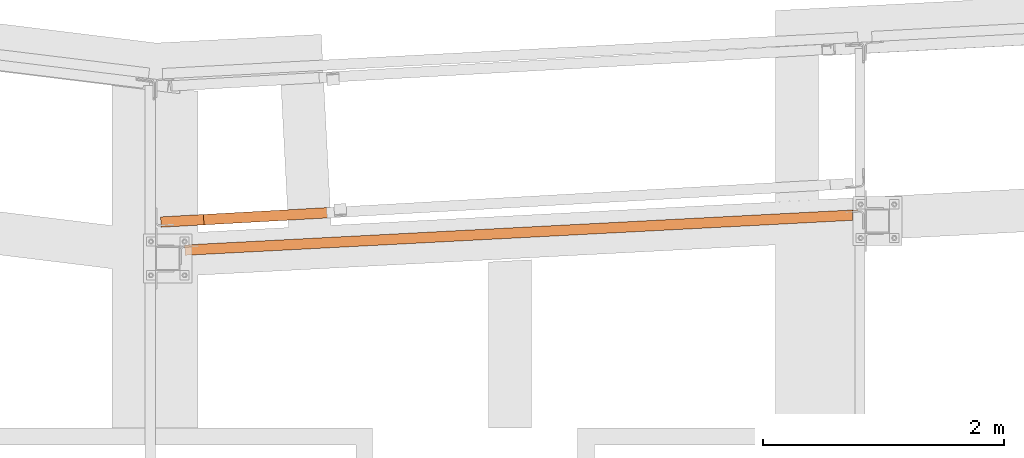
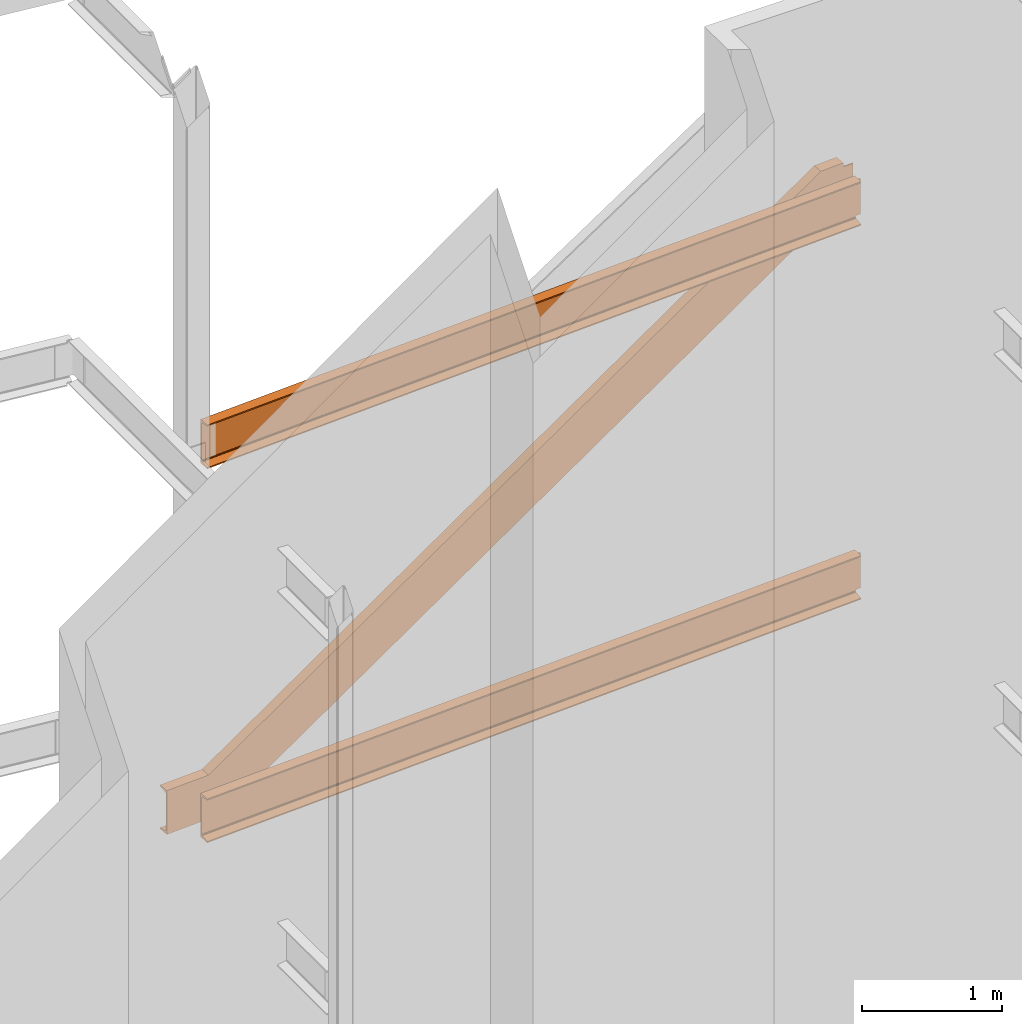
# One storey, part 18 of 89: 3 proxies.
"""IFC4 building model written with IfcOpenShell, lengths in feet."""

import ifcopenshell
import ifcopenshell.guid

model = None  # the IFC model being written
_history = None  # IfcOwnerHistory: only IFC2X3 demands one
_inside = {}  # id of a spatial element -> (the spatial element, [elements in it])
_under = {}  # id of a project, library or spatial element -> (it, [spatial elements below it])
_declared = {}  # id of a project -> (the project, [libraries it declares])
_typed = {}  # id of a type object -> (the type object, [elements of that type])
_made_of = {}  # id of a material, layer set ... -> (it, [elements and type objects made of it])


def new_model(schema):
    """Start an empty IFC model of exactly this schema.

    Asked for "IFC4X3", IfcOpenShell would pick the latest addendum, in which some entities
    have other attributes; the version numbers below select the first issue.
    IFC2X3 requires an IfcOwnerHistory on every rooted entity: one is made here for all.
    """
    global model, _history
    if schema == "IFC4X3":
        model = ifcopenshell.file(schema_version=(4, 3, 0, 0))
    else:
        model = ifcopenshell.file(schema=schema)
    _inside.clear()
    _under.clear()
    _declared.clear()
    _typed.clear()
    _made_of.clear()
    _history = None
    if model.schema == "IFC2X3":
        org = make("IfcOrganization", Name="unknown")
        user = make(
            "IfcPersonAndOrganization",
            ThePerson=make("IfcPerson", FamilyName="unknown"),
            TheOrganization=org,
        )
        app = make(
            "IfcApplication",
            ApplicationDeveloper=org,
            Version="unknown",
            ApplicationFullName="unknown",
            ApplicationIdentifier="unknown",
        )
        _history = make(
            "IfcOwnerHistory",
            OwningUser=user,
            OwningApplication=app,
            ChangeAction="ADDED",
            CreationDate=0,
        )
    return model


def make(cls, **values):
    """One entity of the class cls with the attributes given. An attribute that is None is left unset."""
    return model.create_entity(
        cls, **{name: value for name, value in values.items() if value is not None}
    )


def entity(cls, *values):
    """Any entity or typed value of the class cls, its attributes in the order of the schema. None: left unset."""
    e = model.create_entity(cls)
    for i, value in enumerate(values):
        if value is not None:
            e[i] = value
    return e


def rooted(cls, **values):
    """An entity with a GlobalId (a new one), such as an element, a storey or a relation."""
    return make(cls, GlobalId=ifcopenshell.guid.new(), OwnerHistory=_history, **values)


def si_unit(unit_type, name, prefix=None):
    """IfcSIUnit, for example si_unit("LENGTHUNIT", "METRE", prefix="MILLI")."""
    return make("IfcSIUnit", UnitType=unit_type, Prefix=prefix, Name=name)


def converted_unit(unit_type, name, factor, base, dimensions=None, offset=None):
    """IfcConversionBasedUnit, such as the inch: factor (a typed value) times the base unit."""
    return make(
        "IfcConversionBasedUnit"
        if offset is None
        else "IfcConversionBasedUnitWithOffset",
        ConversionOffset=offset,
        Dimensions=None
        if dimensions is None
        else entity("IfcDimensionalExponents", *dimensions),
        UnitType=unit_type,
        Name=name,
        ConversionFactor=make(
            "IfcMeasureWithUnit", ValueComponent=factor, UnitComponent=base
        ),
    )


def derived_unit(unit_type, elements):
    """IfcDerivedUnit: a product of units, each with its exponent."""
    return make(
        "IfcDerivedUnit",
        Elements=[
            make("IfcDerivedUnitElement", Unit=unit, Exponent=power)
            for unit, power in elements
        ],
        UnitType=unit_type,
    )


def assignment(units):
    """IfcUnitAssignment: the units of a project."""
    return None if units is None else make("IfcUnitAssignment", Units=units)


def point(xyz):
    """IfcCartesianPoint."""
    return None if xyz is None else make("IfcCartesianPoint", Coordinates=xyz)


def direction(xyz):
    """IfcDirection."""
    return None if xyz is None else make("IfcDirection", DirectionRatios=xyz)


def frame(location, z_axis=None, x_axis=None):
    """IfcAxis2Placement3D, a coordinate frame: its origin and axes. An axis left out is left unset."""
    return make(
        "IfcAxis2Placement3D",
        Location=point(location),
        Axis=direction(z_axis),
        RefDirection=direction(x_axis),
    )


def origin():
    """The frame at (0, 0, 0) with its axes left unset."""
    return frame((0.0, 0.0, 0.0))


def place(relative_to, where):
    """IfcLocalPlacement: puts the frame where relative to a parent placement (None: the world)."""
    return make(
        "IfcLocalPlacement", PlacementRelTo=relative_to, RelativePlacement=where
    )


def context(
    kind, dimensions, precision=None, world=None, true_north=None, identifier=None
):
    """IfcGeometricRepresentationContext, for example the 3D "Model" context."""
    return make(
        "IfcGeometricRepresentationContext",
        ContextIdentifier=identifier,
        ContextType=kind,
        CoordinateSpaceDimension=dimensions,
        Precision=precision,
        WorldCoordinateSystem=world,
        TrueNorth=true_north,
    )


def subcontext(parent, identifier, kind, view, scale=None):
    """IfcGeometricRepresentationSubContext, for example "Body" below "Model"."""
    return make(
        "IfcGeometricRepresentationSubContext",
        ContextIdentifier=identifier,
        ContextType=kind,
        ParentContext=parent,
        TargetScale=scale,
        TargetView=view,
    )


def project(units=None, contexts=None):
    """IfcProject with its units and contexts."""
    return rooted(
        "IfcProject",
        Name="project",
        RepresentationContexts=contexts,
        UnitsInContext=assignment(units),
    )


def spatial(cls, under=None, at=None, **own):
    """A site, building, storey or space (cls), placed at a placement, below another one or the project."""
    s = rooted(cls, ObjectPlacement=at, **own)
    if under is not None:
        _under.setdefault(under.id(), (under, []))[1].append(s)
    return s


def faces_of(points, faces, orient=None, outer=None):
    """IfcFace entities. A face is a list of loops; a loop is a list of indices into points, from 0.

    orient and outer hold one flag for each loop. By default every Orientation is true, the
    first loop of a face is its IfcFaceOuterBound and the others are IfcFaceBound.
    """
    made = []
    for i, loops in enumerate(faces):
        bounds = []
        for j, loop in enumerate(loops):
            is_outer = j == 0 if outer is None else outer[i][j]
            bounds.append(
                make(
                    "IfcFaceOuterBound" if is_outer else "IfcFaceBound",
                    Bound=make("IfcPolyLoop", Polygon=[points[k] for k in loop]),
                    Orientation=True if orient is None else orient[i][j],
                )
            )
        made.append(make("IfcFace", Bounds=bounds))
    return made


def face_set(faces, orient=None, outer=None):
    """The faces of one IfcConnectedFaceSet. surface_model builds it on its shared points."""
    return ("IfcConnectedFaceSet", faces, orient, outer)


def faceted_brep(points, faces, orient=None, outer=None, voids=None):
    """IfcFacetedBrep: a solid bounded by flat faces; with voids (closed shells), ...WithVoids."""
    shared = [point(p) for p in points]
    hull = make("IfcClosedShell", CfsFaces=faces_of(shared, faces, orient, outer))
    if voids is None:
        return make("IfcFacetedBrep", Outer=hull)
    return make(
        "IfcFacetedBrepWithVoids",
        Outer=hull,
        Voids=[
            make(cls, CfsFaces=faces_of(shared, fs, o, b)) for cls, fs, o, b in voids
        ],
    )


def surface_model(cls, points, shells):
    """IfcFaceBasedSurfaceModel or IfcShellBasedSurfaceModel (cls): surfaces that need not close."""
    shared = [point(p) for p in points]
    made = [make(c, CfsFaces=faces_of(shared, fs, o, b)) for c, fs, o, b in shells]
    if cls == "IfcFaceBasedSurfaceModel":
        return make(cls, FbsmFaces=made)
    return make(cls, SbsmBoundary=made)


def shape(context_of_items, identifier, shape_type, items):
    """IfcShapeRepresentation: the items that make up one representation, for example the "Body"."""
    return make(
        "IfcShapeRepresentation",
        ContextOfItems=context_of_items,
        RepresentationIdentifier=identifier,
        RepresentationType=shape_type,
        Items=items,
    )


def source(mapping_origin, context_of_items, identifier, shape_type, items):
    """IfcRepresentationMap: a shape defined once, which mapped items show again and again."""
    return make(
        "IfcRepresentationMap",
        MappingOrigin=mapping_origin,
        MappedRepresentation=shape(context_of_items, identifier, shape_type, items),
    )


def transform(
    local_origin,
    x_axis=None,
    y_axis=None,
    z_axis=None,
    scale=None,
    scale2=None,
    scale3=None,
    uniform=True,
):
    """IfcCartesianTransformationOperator3D, or its non-uniform kind. x_axis, y_axis, z_axis: its Axis1, 2, 3."""
    if uniform:
        return make(
            "IfcCartesianTransformationOperator3D",
            Axis1=direction(x_axis),
            Axis2=direction(y_axis),
            LocalOrigin=point(local_origin),
            Scale=scale,
            Axis3=direction(z_axis),
        )
    return make(
        "IfcCartesianTransformationOperator3DnonUniform",
        Axis1=direction(x_axis),
        Axis2=direction(y_axis),
        LocalOrigin=point(local_origin),
        Scale=scale,
        Axis3=direction(z_axis),
        Scale2=scale2,
        Scale3=scale3,
    )


def mapped(mapping_source, mapping_target):
    """IfcMappedItem: shows the shape of a source again, moved by a transform."""
    return make(
        "IfcMappedItem", MappingSource=mapping_source, MappingTarget=mapping_target
    )


def material(Name=None, Category=None):
    """IfcMaterial."""
    return make("IfcMaterial", Name=Name, Category=Category)


def constituent(of_material, Name=None, Category=None, fraction=None):
    """IfcMaterialConstituent: one of the materials an element consists of."""
    return make(
        "IfcMaterialConstituent",
        Name=Name,
        Material=of_material,
        Fraction=fraction,
        Category=Category,
    )


def constituent_set(constituents=None, Name=None):
    """IfcMaterialConstituentSet."""
    return make(
        "IfcMaterialConstituentSet", Name=Name, MaterialConstituents=constituents
    )


def made_of(thing, what):
    """Note that an element or type object is made of a material, layer set ...; save() writes the relation."""
    if what is not None:
        _made_of.setdefault(what.id(), (what, []))[1].append(thing)
    return thing


def type_object(cls, material=None, **own):
    """A type object (cls), such as IfcWallType, which elements share."""
    return made_of(rooted(cls, **own), material)


def type_shapes(of_type, sources):
    """Give a type object the sources (RepresentationMaps) that its elements show as mapped items."""
    of_type.RepresentationMaps = sources


def element(
    cls,
    number,
    at=None,
    inside=None,
    cuts=None,
    type_object=None,
    material=None,
    context=None,
    identifier="Body",
    shape_type=None,
    held_by="IfcProductDefinitionShape",
    body=None,
    shapes=None,
    **own,
):
    """One element of the class cls, such as IfcWall. Its Tag is "e" and its number.

    at: its placement. inside: the storey or other place that contains it. cuts: it is an
    opening in that element (IfcRelVoidsElement). A single representation is given by context,
    identifier, shape_type and body (its items); several are given by shapes. held_by: the class
    of the entity that holds the representations. save() writes the other relations.
    """
    e = rooted(cls, Tag="e%d" % number, ObjectPlacement=at, **own)
    if body is not None:
        shapes = [shape(context, identifier, shape_type, body)]
    if shapes is not None:
        e.Representation = make(held_by, Representations=shapes)
    if inside is not None:
        _inside.setdefault(inside.id(), (inside, []))[1].append(e)
    if cuts is not None:
        rooted(
            "IfcRelVoidsElement", RelatingBuildingElement=cuts, RelatedOpeningElement=e
        )
    if type_object is not None:
        _typed.setdefault(type_object.id(), (type_object, []))[1].append(e)
    return made_of(e, material)


def aggregate(whole, parts):
    """IfcRelAggregates: a whole, such as a stair, and the parts it consists of."""
    return rooted("IfcRelAggregates", RelatingObject=whole, RelatedObjects=parts)


def save(model, path):
    """Write the relations noted so far, then the file.

    IfcRelAggregates (storeys below a building ...), IfcRelContainedInSpatialStructure (elements
    in a storey), IfcRelDefinesByType, IfcRelAssociatesMaterial and IfcRelDeclares: one each for
    every whole, place, type object, material and project.
    """
    for whole, parts in _under.values():
        aggregate(whole, parts)
    for where, things in _inside.values():
        rooted(
            "IfcRelContainedInSpatialStructure",
            RelatedElements=things,
            RelatingStructure=where,
        )
    for kind, things in _typed.values():
        rooted("IfcRelDefinesByType", RelatedObjects=things, RelatingType=kind)
    for what, things in _made_of.values():
        rooted("IfcRelAssociatesMaterial", RelatedObjects=things, RelatingMaterial=what)
    for by, libraries in _declared.values():
        rooted("IfcRelDeclares", RelatingContext=by, RelatedDefinitions=libraries)
    model.write(path)


model = new_model("IFC4")

# Units and contexts
model_context = context("Model", 3, precision=0.0001, world=origin(), true_north=direction((6.12303176911189e-17, 1.0)))
body_context = subcontext(model_context, "Body", "Model", "MODEL_VIEW")
ifc_project = project(units=[converted_unit("LENGTHUNIT", "FOOT", entity("IfcRatioMeasure", 0.3048), si_unit("LENGTHUNIT", "METRE"), dimensions=[1, 0, 0, 0, 0, 0, 0]), converted_unit("AREAUNIT", "SQUARE FOOT", entity("IfcRatioMeasure", 0.09290304), si_unit("AREAUNIT", "SQUARE_METRE"), dimensions=[2, 0, 0, 0, 0, 0, 0]), converted_unit("VOLUMEUNIT", "CUBIC FOOT", entity("IfcRatioMeasure", 0.028316846592), si_unit("VOLUMEUNIT", "CUBIC_METRE"), dimensions=[3, 0, 0, 0, 0, 0, 0]), si_unit("PLANEANGLEUNIT", "RADIAN"), si_unit("MASSUNIT", "GRAM", prefix="KILO"), derived_unit("MASSDENSITYUNIT", [(si_unit("MASSUNIT", "GRAM", prefix="KILO"), 1), (si_unit("LENGTHUNIT", "METRE"), -3)]), derived_unit("MOMENTOFINERTIAUNIT", [(si_unit("LENGTHUNIT", "METRE"), 4)]), si_unit("TIMEUNIT", "SECOND"), si_unit("FREQUENCYUNIT", "HERTZ"), si_unit("THERMODYNAMICTEMPERATUREUNIT", "DEGREE_CELSIUS"), derived_unit("THERMALTRANSMITTANCEUNIT", [(si_unit("MASSUNIT", "GRAM", prefix="KILO"), 1), (si_unit("THERMODYNAMICTEMPERATUREUNIT", "KELVIN"), -1), (si_unit("TIMEUNIT", "SECOND"), -3)]), derived_unit("VOLUMETRICFLOWRATEUNIT", [(si_unit("LENGTHUNIT", "METRE"), 3), (si_unit("TIMEUNIT", "SECOND"), -1)]), si_unit("ELECTRICCURRENTUNIT", "AMPERE"), si_unit("ELECTRICVOLTAGEUNIT", "VOLT"), si_unit("POWERUNIT", "WATT"), si_unit("FORCEUNIT", "NEWTON"), si_unit("ILLUMINANCEUNIT", "LUX"), si_unit("LUMINOUSFLUXUNIT", "LUMEN"), si_unit("LUMINOUSINTENSITYUNIT", "CANDELA"), derived_unit("USERDEFINED", [(si_unit("MASSUNIT", "GRAM", prefix="KILO"), -1), (si_unit("LENGTHUNIT", "METRE"), -2), (si_unit("TIMEUNIT", "SECOND"), 3), (si_unit("LUMINOUSFLUXUNIT", "LUMEN"), 1)]), derived_unit("LINEARVELOCITYUNIT", [(si_unit("LENGTHUNIT", "METRE"), 1), (si_unit("TIMEUNIT", "SECOND"), -1)]), si_unit("PRESSUREUNIT", "PASCAL"), derived_unit("USERDEFINED", [(si_unit("LENGTHUNIT", "METRE"), -2), (si_unit("MASSUNIT", "GRAM", prefix="KILO"), 1), (si_unit("TIMEUNIT", "SECOND"), -2)]), derived_unit("LINEARFORCEUNIT", [(si_unit("MASSUNIT", "GRAM", prefix="KILO"), 1), (si_unit("LENGTHUNIT", "METRE"), 1), (si_unit("TIMEUNIT", "SECOND"), -2), (si_unit("LENGTHUNIT", "METRE"), -1)]), derived_unit("PLANARFORCEUNIT", [(si_unit("MASSUNIT", "GRAM", prefix="KILO"), 1), (si_unit("LENGTHUNIT", "METRE"), 1), (si_unit("TIMEUNIT", "SECOND"), -2), (si_unit("LENGTHUNIT", "METRE"), -2)])], contexts=[model_context])

# Site, building, storey
site_placement = place(None, origin())
site = spatial("IfcSite", under=ifc_project, at=site_placement, CompositionType="ELEMENT")
building_placement = place(site_placement, frame((-472.238160486, -49.138065117, 0.0)))
building = spatial("IfcBuilding", under=site, at=building_placement, CompositionType="ELEMENT")
storey_placement = place(building_placement, origin())
storey = spatial("IfcBuildingStorey", under=building, at=storey_placement, Name="Level 1", CompositionType="ELEMENT", Elevation=0.0)

# Proxies
ifc_material_1 = material(Name="Color 7720", Category="Materials")
ifc_material_2 = material()
ifc_constituent_1 = constituent(ifc_material_2)
ifc_constituent_2 = constituent(ifc_material_1, Name="Color 7720", Category="Materials")
ifc_constituent_set_1 = constituent_set(constituents=[ifc_constituent_1, ifc_constituent_2])
building_element_proxy_type_1 = type_object("IfcBuildingElementProxyType", Name="B_103", PredefinedType="NOTDEFINED", material=ifc_constituent_set_1)
shared_shape_1 = source(origin(), body_context, "Body", "Brep", [
    faceted_brep([(0.0, 0.282945034847216, 1.25), (0.0, 0.282945034847216, 0.0), (0.0148285209357937, 0.0, 0.0), (0.0148285209357937, 0.0, 0.0333340558078792), (0.00405689048204749, 0.205534953036704, 0.0676357025785492), (0.00314508419057802, 0.222933253516999, 0.0738152303316895), (0.00240032733222506, 0.2371440609312, 0.0856142600983691), (0.00191364833358421, 0.246430449426384, 0.10159064723195), (0.00174453187503332, 0.249657383688714, 0.11979166666667), (0.00174453187503332, 0.249657383688714, 1.13020833333333), (0.00191364833358421, 0.246430449426384, 1.14840935276805), (0.00240032733222506, 0.2371440609312, 1.16438573990163), (0.00314508419057802, 0.222933253516999, 1.17618476966831), (0.00405689048204749, 0.205534953036704, 1.18236429742145), (0.0148285209357937, 0.0, 1.21666594419212), (0.0148285209357937, 0.0, 1.25), (18.3394481723241, 1.2440747868352, 0.125), (18.3394481723241, 1.2440747868352, 1.125), (18.3411927041989, 1.2107871356767, 1.125), (18.3411927041989, 1.2107871356767, 0.125), (18.2195009717029, 1.23778862041866, 0.121828313854641), (18.2060018576239, 1.2370811618274, 0.11279611588277), (18.1969820379654, 1.23660845310962, 0.0992784763485499), (18.1938146985058, 1.23644245988226, 0.0833333333333304), (18.1938146985058, 1.23644245988226, 0.0), (18.1938146985057, 1.23644245988271, 1.25), (18.1938146985057, 1.23644245988271, 1.16666666666667), (18.1969820379654, 1.23660845310997, 1.15072152365145), (18.2060018576238, 1.23708116182775, 1.13720388411723), (18.2195009717029, 1.237788620419, 1.12817168614536), (18.2354242624539, 1.23862312472613, 1.125), (18.2354242624539, 1.23862312472579, 0.125), (18.1989937882446, 0.952991719775582, 0.0), (18.1989937775089, 1.1376197455063, 0.0), (18.1989937882446, 0.952991719775582, 0.0333340558078792), (18.1989937775089, 1.1376197455063, 0.0640621568246083), (18.1978715889875, 1.15903237807242, 0.067635702578567), (18.1969597826961, 1.17643067855295, 0.073815230331709), (18.1966681085939, 1.19066523102811, 0.0856142600982892), (18.1963589983409, 1.18789432695269, 0.0833333333332256), (18.2004385121994, 1.2001747237689, 0.101590647231927), (18.1989661205591, 1.19874990194126, 0.0992784763485393), (18.2182016229171, 1.20434144623516, 0.119791666666641), (18.2078113893069, 1.20255324044274, 0.112796115882762), (18.2371687943287, 1.20533547356729, 0.125), (18.2371687943287, 1.20533547356729, 1.125), (18.2212455035777, 1.20450096926015, 1.12817168614536), (18.2182016229172, 1.20434144623437, 1.13020833333333), (18.2212455035777, 1.20450096926015, 0.121828313854641), (18.2004385121994, 1.2001747237689, 1.14840935276808), (18.2078113893069, 1.20255324044274, 1.13720388411723), (18.1966681085939, 1.19066523102822, 1.16438573990165), (18.1989661205591, 1.19874990194126, 1.15072152365147), (18.1969597826961, 1.17643067855295, 1.17618476966834), (18.1963589983409, 1.18789432695269, 1.16666666666681), (18.1978715889875, 1.15903237807242, 1.18236429742147), (18.1989937882446, 0.952991719775582, 1.2166659441921), (18.1989937775089, 1.1376197455063, 1.18593784317542), (18.1989937882446, 0.952991719775582, 1.25), (18.1989937775089, 1.1376197455063, 1.25)], [[[0, 1, 2, 3, 4, 5, 6, 7, 8, 9, 10, 11, 12, 13, 14, 15]], [[16, 17, 18, 19]], [[20, 21, 22, 23, 24, 1, 0, 25, 26, 27, 28, 29, 30, 17, 16, 31]], [[32, 2, 1, 24, 33]], [[34, 3, 2, 32]], [[35, 36, 4, 3, 34]], [[37, 5, 4, 36]], [[38, 6, 5, 37, 39]], [[40, 7, 6, 38, 41]], [[42, 8, 7, 40, 43]], [[44, 19, 18, 45, 46, 47, 9, 8, 42, 48]], [[49, 10, 9, 47, 50]], [[51, 11, 10, 49, 52]], [[53, 12, 11, 51, 54]], [[55, 13, 12, 53]], [[56, 14, 13, 55, 57]], [[58, 15, 14, 56]], [[59, 25, 0, 15, 58]], [[57, 59, 25, 26, 54, 53, 55]], [[52, 27, 26, 54, 51]], [[50, 28, 27, 52, 49]], [[46, 29, 28, 50, 47]], [[29, 46, 45, 30]], [[17, 30, 45, 18]], [[59, 58, 56, 57]], [[19, 44, 31, 16]], [[48, 20, 31, 44]], [[43, 21, 20, 48, 42]], [[41, 22, 21, 43, 40]], [[39, 23, 22, 41, 38]], [[33, 24, 23, 39, 37, 36, 35]], [[34, 32, 33, 35]]]),
])
type_shapes(building_element_proxy_type_1, [shared_shape_1])
proxy_1_placement = place(building_placement, frame((289.291038536762, 1012.70382033121, 8.35416666666667)))
element("IfcBuildingElementProxy", 1, at=proxy_1_placement, inside=storey, type_object=building_element_proxy_type_1, material=ifc_material_1, Name="B_103:B_103", ObjectType="B_103:B_103", PredefinedType="NOTDEFINED", context=body_context, shape_type="MappedRepresentation", body=[
    mapped(shared_shape_1, transform((0.0, 0.0, 0.0), scale=1.0)),
])
ifc_constituent_3 = constituent(ifc_material_2)
ifc_constituent_4 = constituent(ifc_material_1, Name="Color 7720", Category="Materials")
ifc_constituent_set_2 = constituent_set(constituents=[ifc_constituent_3, ifc_constituent_4])
building_element_proxy_type_2 = type_object("IfcBuildingElementProxyType", Name="20B1", PredefinedType="NOTDEFINED", material=ifc_constituent_set_2)
shared_shape_2 = source(origin(), body_context, "Body", "Brep", [
    faceted_brep([(0.0, 0.282945034847444, 1.25), (0.0, 0.282945034847444, 0.0), (0.01482852093568, 0.0, 0.0), (0.01482852093568, 0.0, 0.0333340558078774), (0.00405689048199065, 0.205534953036818, 0.0676357025785457), (0.00314508419052117, 0.222933253517112, 0.0738152303316859), (0.00240032733211137, 0.237144060931314, 0.0856142600983674), (0.00191364833352736, 0.246430449426498, 0.101590647231948), (0.00174453187497647, 0.249657383688827, 0.119791666666668), (0.00174453187497647, 0.249657383688827, 1.13020833333333), (0.00191364833352736, 0.246430449426498, 1.14840935276805), (0.00240032733211137, 0.237144060931314, 1.16438573990163), (0.00314508419052117, 0.222933253517112, 1.17618476966831), (0.00405689048199065, 0.205534953036818, 1.18236429742144), (0.01482852093568, 0.0, 1.21666594419212), (0.01482852093568, 0.0, 1.25), (18.339448172324, 1.24407478683543, 0.124999999999996), (18.339448172324, 1.24407478683543, 1.125), (18.3411927041988, 1.21078713567681, 1.125), (18.3411927041988, 1.21078713567681, 0.124999999999996), (18.219500971703, 1.23778862041775, 0.121828313854635), (18.206001857624, 1.23708116182661, 0.112796115882766), (18.1969820379655, 1.23660845310872, 0.0992784763485375), (18.1938146985058, 1.23644245988135, 0.083333333333325), (18.1938146985058, 1.23644245988112, 0.0), (18.1938146985056, 1.23644245988407, 1.25), (18.1938146985056, 1.23644245988396, 1.16666666666666), (18.1969820379654, 1.23660845311122, 1.15072152365145), (18.2060018576238, 1.237081161829, 1.13720388411722), (18.2195009717029, 1.23778862042013, 1.12817168614536), (18.2354242624538, 1.23862312472727, 1.125), (18.2354242624539, 1.23862312472488, 0.124999999999996), (18.1989937882445, 0.952991719775696, 0.0), (18.1989937775089, 1.13761974550641, 0.0), (18.1989937882445, 0.952991719775696, 0.0333340558078774), (18.1989937775089, 1.13761974550641, 0.0640621568245869), (18.1978715889875, 1.15903237807254, 0.0676357025785457), (18.196959782696, 1.17643067855306, 0.0738152303317072), (18.196668108594, 1.19066523102822, 0.0856142600983674), (18.1963589983409, 1.18789432695269, 0.083333333333254), (18.2004385121994, 1.20017472376878, 0.101590647231909), (18.1989661205591, 1.19874990194114, 0.0992784763485517), (18.2182016229172, 1.20434144623505, 0.119791666666675), (18.207811389307, 1.20255324044263, 0.112796115882794), (18.2371687943286, 1.2053354735674, 0.124999999999996), (18.2371687943286, 1.2053354735674, 1.125), (18.2212455035777, 1.20450096926027, 1.12817168614536), (18.2182016229172, 1.20434144623448, 1.13020833333333), (18.2212455035777, 1.20450096926027, 0.121828313854635), (18.2004385121994, 1.20017472376878, 1.14840935276805), (18.207811389307, 1.20255324044251, 1.1372038841172), (18.196668108594, 1.19066523102822, 1.16438573990161), (18.1989661205591, 1.19874990194126, 1.15072152365143), (18.196959782696, 1.17643067855306, 1.17618476966826), (18.1963589983409, 1.1878943269528, 1.16666666666673), (18.1978715889875, 1.15903237807254, 1.18236429742147), (18.1989937882445, 0.952991719775696, 1.2166659441921), (18.1989937775089, 1.13761974550641, 1.18593784317542), (18.1989937882445, 0.952991719775696, 1.25), (18.1989937775089, 1.13761974550641, 1.25)], [[[0, 1, 2, 3, 4, 5, 6, 7, 8, 9, 10, 11, 12, 13, 14, 15]], [[16, 17, 18, 19]], [[20, 21, 22, 23, 24, 1, 0, 25, 26, 27, 28, 29, 30, 17, 16, 31]], [[32, 2, 1, 24, 33]], [[34, 3, 2, 32]], [[35, 36, 4, 3, 34]], [[37, 5, 4, 36]], [[38, 6, 5, 37, 39]], [[40, 7, 6, 38, 41]], [[42, 8, 7, 40, 43]], [[44, 19, 18, 45, 46, 47, 9, 8, 42, 48]], [[49, 10, 9, 47, 50]], [[51, 11, 10, 49, 52]], [[53, 12, 11, 51, 54]], [[55, 13, 12, 53]], [[56, 14, 13, 55, 57]], [[58, 15, 14, 56]], [[59, 25, 0, 15, 58]], [[57, 59, 25, 26, 54, 53, 55]], [[52, 27, 26, 54, 51]], [[50, 28, 27, 52, 49]], [[46, 29, 28, 50, 47]], [[29, 46, 45, 30]], [[17, 30, 45, 18]], [[59, 58, 56, 57]], [[19, 44, 31, 16]], [[48, 20, 31, 44]], [[43, 21, 20, 48, 42]], [[41, 22, 21, 43, 40]], [[39, 23, 22, 41, 38]], [[33, 24, 23, 39, 37, 36, 35]], [[34, 32, 33, 35]]]),
])
type_shapes(building_element_proxy_type_2, [shared_shape_2])
proxy_2_placement = place(building_placement, frame((289.291038536762, 1012.70382033121, 19.0208333333333)))
element("IfcBuildingElementProxy", 2, at=proxy_2_placement, inside=storey, type_object=building_element_proxy_type_2, material=ifc_material_1, Name="20B1:20B1", ObjectType="20B1:20B1", PredefinedType="NOTDEFINED", context=body_context, shape_type="MappedRepresentation", body=[
    mapped(shared_shape_2, transform((0.0, 0.0, 0.0), scale=1.0)),
])
ifc_material_3 = material(Name="Color 7718", Category="Materials")
ifc_constituent_5 = constituent(ifc_material_3, Name="Color 7718", Category="Materials")
ifc_constituent_6 = constituent(ifc_material_1, Name="Color 7720", Category="Materials")
ifc_constituent_set_3 = constituent_set(constituents=[ifc_constituent_5, ifc_constituent_6])
ifc_constituent_7 = constituent(ifc_material_2)
ifc_constituent_8 = constituent(ifc_material_3, Name="Color 7718", Category="Materials")
ifc_constituent_set_4 = constituent_set(constituents=[ifc_constituent_7, ifc_constituent_8])
building_element_proxy_type_3 = type_object("IfcBuildingElementProxyType", Name="c633", PredefinedType="NOTDEFINED", material=ifc_constituent_set_4)
shared_shape_3 = source(origin(), body_context, "Body", "SurfaceModel", [
    surface_model("IfcFaceBasedSurfaceModel", [(0.0, 0.282893515539058, 1.21666605017325), (0.0, 0.282893515539058, 1.25000010598113), (0.0157808948881097, 0.0, 1.25000010598113), (0.0157808948881097, 0.0, 1.05981133202704e-07), (0.0, 0.282893515539058, 1.05981133202704e-07), (0.0, 0.282893515539058, 0.0333341617890124), (0.0114634472785724, 0.0773959867976828, 0.0676358085596824), (0.0124338150790209, 0.0600008542412525, 0.0738153363128227), (0.013226404559191, 0.0457926343649433, 0.0856143660795023), (0.0137443409167304, 0.03650793675763, 0.101590753213083), (0.0139243190189404, 0.0332815900630976, 0.119791772647803), (0.0139243190189404, 0.0332815900630976, 1.13020843931447), (0.0137443409167304, 0.03650793675763, 1.14840945874918), (0.013226404559191, 0.0457926343649433, 1.16438584588277), (0.0124338150790209, 0.0600008542412525, 1.17618487564944), (0.0114634472785724, 0.0773959867976828, 1.18236440340258), (1.1829579478117, 0.0651096521353338, 1.25000010598113), (1.54041586807739, 0.0850500380290669, 1.05981133202704e-07), (1.52463497321219, 0.367943553569262, 1.05981133202704e-07), (1.51510255537875, 0.367411798419084, 0.0333341617890124), (1.51675688640427, 0.161367079219076, 0.0676358085596735), (1.51596011729362, 0.143873368928098, 0.0738153363129008), (1.51337858146047, 0.129476927286532, 0.0856143660796391), (1.50932780892356, 0.119937369419631, 0.101590753213188), (1.50430290818275, 0.116420674444271, 0.119791772647856), (1.215357755968, 0.100302195846666, 1.13020843931447), (1.20997289902266, 0.103238194260143, 1.14840945874917), (1.20488625377067, 0.112268031607982, 1.16438584588269), (1.20071953897724, 0.126288029718921, 1.17618487564922), (1.19798203426575, 0.143584584540804, 1.18236440340245), (1.17670947073407, 0.348534922823319, 1.21666605017315), (1.16717705292353, 0.348003167674392, 1.25000010598113), (19.146723637029, 1.06719077166008, 10.7812494701983), (19.1448620647633, 1.10045493181633, 10.7864584393145), (19.146723637029, 1.06719077166008, 11.8020834393145), (19.1448620647633, 1.10057700212883, 10.7812494701983), (19.1448620647633, 1.10057700212883, 11.7973436779619), (19.1448620647633, 1.10057700212883, 11.8020834393145), (18.234370121404, 1.30010092791008, 11.9166674084307), (18.2439221233571, 1.30058920916008, 11.883332676375), (18.2651928753102, 1.09563315447258, 11.8490309185625), (18.2679089397633, 1.07836020525383, 11.8428511089922), (18.2501477092946, 1.01720297869133, 11.9166674084307), (18.2720898479665, 1.06432211931633, 11.8310522503496), (18.2771862835133, 1.05528891619133, 11.8150762982012), (18.2825573772633, 1.05235922869133, 11.7968744701983), (18.5714978069508, 1.06847250994133, 10.7864584393145), (18.5831555217946, 1.09593833025383, 10.7404818005205), (18.5839489788258, 1.11345542009758, 10.7343019909502), (18.6076306194508, 1.03710043962883, 10.6666674084307), (18.5823010296071, 1.31951010759758, 10.7000002331377), (18.5918530315602, 1.31999838884758, 10.6666674084307), (18.5765332073415, 1.07201254900383, 10.7682566113115), (18.5805920452321, 1.08153403337883, 10.7522806591631), (18.8763073772633, 1.05211508806633, 11.8437494701983), (18.8763073772633, 1.05211508806633, 11.9166674084307), (18.8794812053883, 1.05229819353508, 11.8278040356279), (18.8885144085133, 1.05278647478508, 11.8142866558672), (18.9179028362477, 1.05443442400383, 10.7812494701983), (18.9179028362477, 1.05443442400383, 11.8020834393145), (18.9020031780446, 1.05351889666008, 11.8052553600908), (18.8885144085133, 1.05278647478508, 10.7690462536455), (18.8794812053883, 1.05229819353508, 10.7555288738848), (18.8763073772633, 1.05211508806633, 10.7395834393145), (18.8763073772633, 1.05211508806633, 10.6666674084307), (18.9020031780446, 1.05351889666008, 10.7780775494219), (18.8605297893727, 1.33501303728508, 10.6666674084307), (18.8721264690602, 1.12706625994133, 10.6666674084307), (18.8605297893727, 1.33501303728508, 10.7000002331377), (18.8720043987477, 1.12950766619133, 10.7343019909502), (18.8721264690602, 1.12706625994133, 10.7351660198809), (18.8728283733571, 1.11461508806633, 10.7395834393145), (18.8731335491383, 1.11211264666008, 10.7404818005205), (18.8762768596852, 1.09807456072258, 10.7522806591631), (18.8770397991383, 1.09618247087883, 10.7555288738848), (18.8859509319508, 1.08928549822258, 10.7682566113115), (18.886469730779, 1.08916342791008, 10.7690462536455), (18.9000500530446, 1.08830893572258, 10.7780775494219), (18.9108532757008, 1.08855307634758, 10.7802271313311), (18.9160412639821, 1.08782065447258, 10.7859892315508), (18.9108532757008, 1.08855307634758, 11.8031057781817), (18.9160412639821, 1.08782065447258, 11.7973436779619), (18.9000500530446, 1.08830893572258, 11.8052553600908), (18.886469730779, 1.08916342791008, 11.8142866558672), (18.8859509319508, 1.08928549822258, 11.8150762982012), (18.8770397991383, 1.09618247087883, 11.8278040356279), (18.8762768596852, 1.09807456072258, 11.8310522503496), (18.8731335491383, 1.11211264666008, 11.8428511089922), (18.8728283733571, 1.11461508806633, 11.8437494701983), (18.8721264690602, 1.12706625994133, 11.8481687969805), (18.8720043987477, 1.12950766619133, 11.8490309185625), (18.8605297893727, 1.33501303728508, 11.883332676375), (18.8605297893727, 1.33501303728508, 11.9166674084307), (18.8721264690602, 1.12706625994133, 11.9166674084307), (18.9160412639821, 1.08782065447258, 11.8020834393145), (18.9160412639821, 1.08782065447258, 10.7812494701983)], [face_set([[[0, 1, 2, 3, 4, 5, 6, 7, 8, 9, 10, 11, 12, 13, 14, 15]], [[16, 2, 3, 17]], [[17, 3, 4, 18]], [[18, 4, 5, 19]], [[19, 5, 6, 20]], [[20, 6, 7, 21]], [[21, 7, 8, 22]], [[22, 8, 9, 23]], [[23, 9, 10, 24]], [[24, 10, 11, 25]], [[25, 11, 12, 26]], [[26, 12, 13, 27]], [[27, 13, 14, 28]], [[28, 14, 15, 29]], [[29, 15, 0, 30]], [[30, 0, 1, 31]], [[31, 1, 2, 16]], [[18, 19, 20, 21, 22, 23, 24, 25, 26, 27, 28, 29, 30, 31, 16, 17]]]), face_set([[[32, 33, 34]], [[33, 32, 35]], [[36, 34, 33]], [[34, 36, 37]], [[38, 39, 40]], [[40, 41, 42]], [[38, 40, 42]], [[42, 43, 44]], [[43, 42, 41]], [[44, 45, 42]], [[42, 45, 46]], [[47, 48, 49]], [[50, 51, 48]], [[48, 51, 49]], [[46, 52, 49]], [[53, 49, 52]], [[49, 53, 47]], [[46, 49, 42]], [[54, 55, 42]], [[56, 42, 57]], [[42, 56, 54]], [[58, 59, 60]], [[60, 57, 61]], [[34, 59, 32]], [[49, 57, 42]], [[62, 61, 49]], [[63, 49, 64]], [[49, 63, 62]], [[65, 60, 61]], [[58, 32, 59]], [[58, 60, 65]], [[61, 57, 49]], [[51, 66, 67]], [[67, 64, 49]], [[67, 49, 51]], [[68, 66, 51]], [[51, 50, 68]], [[69, 68, 50]], [[50, 48, 69]], [[70, 69, 48]], [[71, 48, 47]], [[48, 71, 70]], [[71, 47, 72]], [[73, 72, 47]], [[47, 53, 73]], [[74, 73, 53]], [[74, 52, 75]], [[52, 74, 53]], [[52, 46, 75]], [[76, 75, 46]], [[46, 77, 76]], [[78, 77, 79]], [[33, 79, 46]], [[77, 46, 79]], [[46, 45, 36]], [[36, 33, 46]], [[80, 81, 82]], [[36, 45, 81]], [[82, 45, 83]], [[45, 82, 81]], [[45, 84, 83]], [[84, 45, 44]], [[85, 84, 44]], [[86, 44, 43]], [[44, 86, 85]], [[87, 86, 43]], [[43, 41, 87]], [[87, 88, 41]], [[41, 88, 89]], [[90, 40, 41]], [[90, 41, 89]], [[91, 90, 40]], [[40, 39, 91]], [[92, 91, 39]], [[39, 38, 92]], [[93, 38, 42]], [[38, 93, 92]], [[93, 42, 55]], [[37, 94, 59]], [[59, 34, 37]], [[59, 94, 80]], [[80, 82, 60]], [[80, 60, 59]], [[83, 57, 82]], [[60, 82, 57]], [[85, 56, 84]], [[84, 57, 83]], [[57, 84, 56]], [[87, 88, 54]], [[86, 87, 54]], [[85, 54, 56]], [[54, 85, 86]], [[93, 88, 89]], [[55, 54, 88]], [[89, 90, 93]], [[91, 92, 93]], [[55, 88, 93]], [[93, 90, 91]], [[80, 94, 81]], [[36, 81, 94]], [[94, 37, 36]], [[67, 71, 70]], [[64, 63, 71]], [[70, 69, 67]], [[68, 66, 67]], [[64, 71, 67]], [[67, 69, 68]], [[72, 73, 63]], [[71, 72, 63]], [[74, 62, 63]], [[74, 63, 73]], [[76, 61, 75]], [[75, 62, 74]], [[62, 75, 61]], [[61, 76, 77]], [[77, 65, 61]], [[77, 78, 65]], [[58, 65, 78]], [[58, 78, 95]], [[95, 35, 58]], [[32, 58, 35]], [[79, 95, 78]], [[95, 79, 35]], [[33, 35, 79]]])]),
    surface_model("IfcFaceBasedSurfaceModel", [(1.16717705292353, 0.348003167679508, 1.25000010598105), (1.17670946621195, 0.348534922576164, 1.21666604734694), (1.1979820250902, 0.143584584033874, 1.18236439766801), (1.20071952896342, 0.126288029165266, 1.17618486939093), (1.20488624215614, 0.11226803096497, 1.16438583862389), (1.20997288524086, 0.103238193496281, 1.14840945013574), (1.21535773971704, 0.100302194945016, 1.13020842915786), (1.50430275485928, 0.116420665895816, 0.119791676823315), (1.50932765313098, 0.119937360733729, 0.101590655845428), (1.51337842350063, 0.129476918479895, 0.0856142673572915), (1.51595995773306, 0.143873360032217, 0.0738152365902334), (1.51675672600538, 0.161367070276356, 0.0676357083131602), (1.5151023903266, 0.367411789216931, 0.0333340586342494), (1.52463480361502, 0.367943544113587, 0.0), (1.54041569850307, 0.0850500285740736, 0.0), (1.18295794781159, 0.065109652139995, 1.25000010598102), (18.250161593496, 1.01718430911546, 11.9166667726478), (18.6076193441867, 1.03712468554954, 10.6666666666667), (18.5918384492985, 1.32001820108906, 10.6666666666667), (18.5823060360102, 1.3194864461924, 10.7000007253008), (18.583960371689, 1.11344172725171, 10.7343023749797), (18.5831636034167, 1.09594801700769, 10.7404819032568), (18.5805820691843, 1.08155157545536, 10.7522809340239), (18.5765312988147, 1.07201201770908, 10.768257322512), (18.571506400543, 1.06849532287129, 10.7864583434899), (18.2825613854014, 1.05237685192049, 11.7968750958246), (18.2771765309253, 1.05531285047175, 11.8150761168025), (18.2720898878405, 1.06434268794033, 11.8310525052907), (18.2679231746478, 1.07836268614062, 11.8428515360577), (18.2651856707746, 1.09565924100934, 11.8490310643348), (18.2439131118963, 1.30060957955163, 11.8833327140137), (18.2343806986079, 1.30007782465498, 11.9166667726478)], [face_set([[[0, 1, 2, 3, 4, 5, 6, 7, 8, 9, 10, 11, 12, 13, 14, 15]], [[16, 17, 18, 19, 20, 21, 22, 23, 24, 25, 26, 27, 28, 29, 30, 31]], [[30, 1, 0, 31]], [[29, 2, 1, 30]], [[28, 3, 2, 29]], [[27, 4, 3, 28]], [[26, 5, 4, 27]], [[25, 6, 5, 26]], [[24, 7, 6, 25]], [[23, 8, 7, 24]], [[22, 9, 8, 23]], [[21, 10, 9, 22]], [[20, 11, 10, 21]], [[19, 12, 11, 20]], [[18, 13, 12, 19]], [[17, 14, 13, 18]], [[16, 15, 14, 17]], [[31, 0, 15, 16]]])]),
])
type_shapes(building_element_proxy_type_3, [shared_shape_3])
proxy_3_placement = place(building_placement, frame((288.637669673518, 1013.46894204084, 8.35416656068553)))
element("IfcBuildingElementProxy", 3, at=proxy_3_placement, inside=storey, type_object=building_element_proxy_type_3, material=ifc_constituent_set_3, Name="c633:c633", ObjectType="c633:c633", PredefinedType="NOTDEFINED", context=body_context, shape_type="MappedRepresentation", body=[
    mapped(shared_shape_3, transform((0.0, 0.0, 0.0), scale=1.0)),
])

save(model, "model.ifc")
